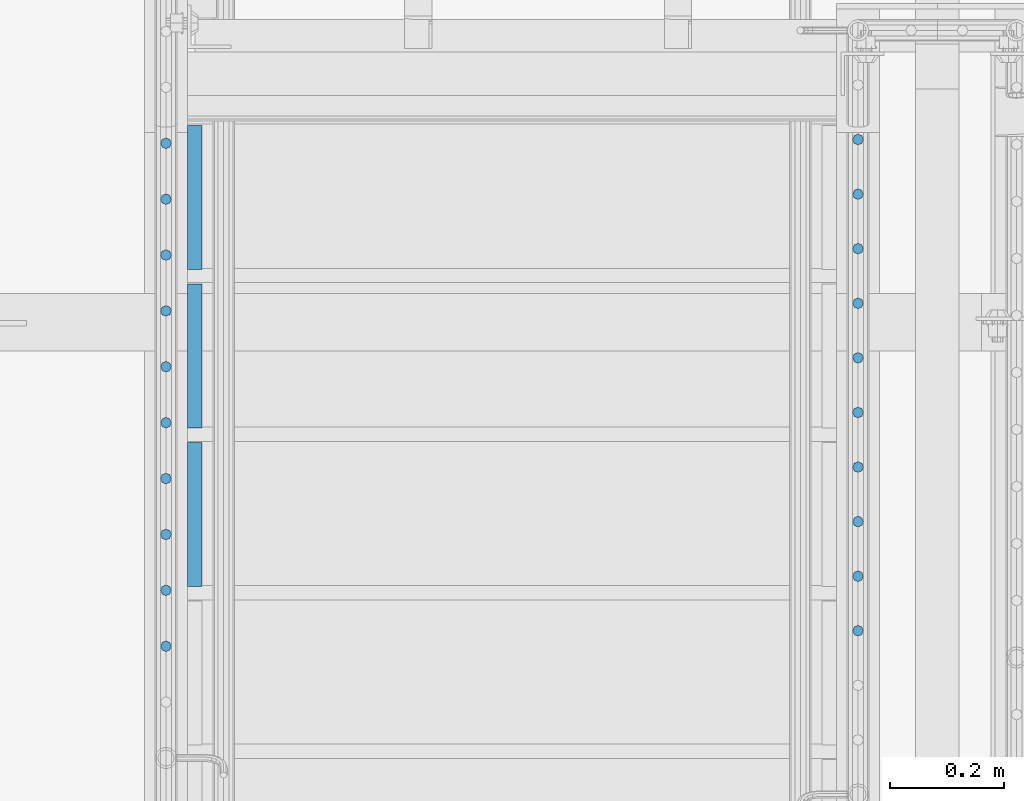
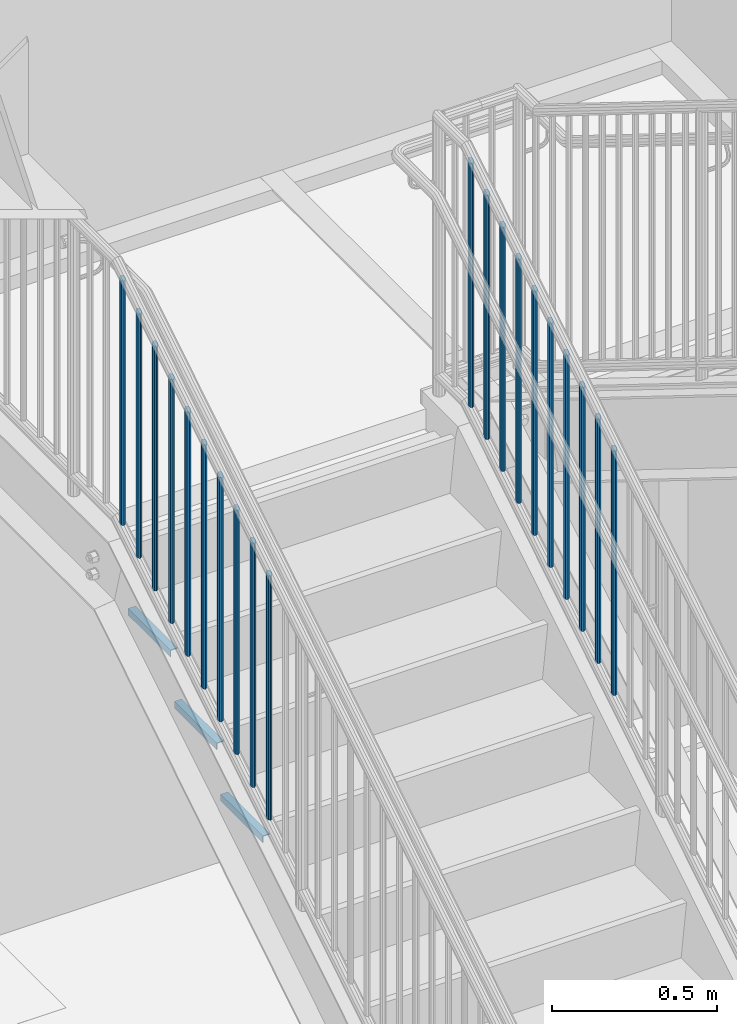
# One storey, part 1271 of 1763: 23 beams, 3 elements without a shape of their own.
"""IFC2X3 building model written with IfcOpenShell, lengths in millimetres."""

from ifc_helpers import new_model, si_unit, frame, origin_with_axes, place, context, subcontext, project, spatial, faceted_brep, material, type_object, element, aggregate, save


model = new_model("IFC2X3")

# Units and contexts
model_context = context("Model", 3, precision=1e-05, world=origin_with_axes())
body_context = subcontext(model_context, "Body", "Model", "MODEL_VIEW")
ifc_project = project(units=[si_unit("LENGTHUNIT", "METRE", prefix="MILLI"), si_unit("AREAUNIT", "SQUARE_METRE"), si_unit("VOLUMEUNIT", "CUBIC_METRE"), si_unit("MASSUNIT", "GRAM", prefix="KILO"), si_unit("TIMEUNIT", "SECOND"), si_unit("PLANEANGLEUNIT", "RADIAN"), si_unit("SOLIDANGLEUNIT", "STERADIAN"), si_unit("THERMODYNAMICTEMPERATUREUNIT", "DEGREE_CELSIUS"), si_unit("LUMINOUSINTENSITYUNIT", "LUMEN")], contexts=[model_context])

# Site, building, storey
site_placement = place(None, origin_with_axes())
site = spatial("IfcSite", under=ifc_project, at=site_placement, CompositionType="ELEMENT")
building_placement = place(site_placement, origin_with_axes())
building = spatial("IfcBuilding", under=site, at=building_placement, Name="Undefined", CompositionType="ELEMENT")
storey_placement = place(building_placement, origin_with_axes())
storey = spatial("IfcBuildingStorey", under=building, at=storey_placement, Name="Undefined", CompositionType="ELEMENT", Elevation=0.0)

# Assembly, beams
assembly_1_placement = place(storey_placement, origin_with_axes())
assembly_1 = element("IfcElementAssembly", 1, at=assembly_1_placement, inside=storey, Name="RAIL", AssemblyPlace="NOTDEFINED", PredefinedType="RIGID_FRAME")
ifc_material = material(Name="STEEL/A36")
beam_type_1 = type_object("IfcBeamType", PredefinedType="NOTDEFINED")
beam_1_placement = place(assembly_1_placement, frame((-85559.3372736932, 35901.0857146553, 3782.00006697853), z_axis=(-1.0, 0.0, 0.0), x_axis=(0.0, 0.0, -1.0)))
beam_1 = element("IfcBeam", 2, at=beam_1_placement, type_object=beam_type_1, material=ifc_material, Name="PICKET", context=body_context, shape_type="Brep", body=[
    faceted_brep([(18.2402825153672, -6.73519209080405, 6.73519209079677), (22.4197092545201, 0.0, 9.52499999999418), (26.5991359936734, 6.73519209080405, 6.73519209079677), (28.330311231975, 9.52500000000146, 0.0), (26.5991359936734, 6.73519209080405, -6.73519209079677), (22.4197092545201, 0.0, -9.52499999999418), (18.2402825153672, -6.73519209080405, -6.73519209079677), (16.5091072770651, -9.52500000000146, 0.0), (929.64089275145, 9.52500000000146, 0.0), (927.909717513148, 6.73519209080405, -6.73519209079677), (923.730290773995, 0.0, -9.52499999999418), (919.550864034841, -6.73519209080405, -6.73519209079677), (917.819688796539, -9.52500000000146, 0.0), (919.550864034841, -6.73519209080405, 6.73519209079677), (923.730290773995, 0.0, 9.52499999999418), (927.909717513148, 6.73519209080405, 6.73519209079677)], [[[0, 1, 2, 3, 4, 5, 6, 7]], [[4, 3, 8, 9]], [[5, 4, 9, 10]], [[6, 5, 10, 11]], [[7, 6, 11, 12]], [[0, 7, 12, 13]], [[1, 0, 13, 14]], [[2, 1, 14, 15]], [[3, 2, 15, 8]], [[14, 13, 12, 11, 10, 9, 8, 15]]]),
])
beam_2_placement = place(assembly_1_placement, frame((-85559.3372736932, 35804.9285717983, 3722.33113272945), z_axis=(-1.0, 0.0, 0.0), x_axis=(0.0, 0.0, -1.0)))
beam_2 = element("IfcBeam", 3, at=beam_2_placement, type_object=beam_type_1, material=ifc_material, Name="PICKET", context=body_context, shape_type="Brep", body=[
    faceted_brep([(16.5091072770651, -9.52500000000146, 0.0), (18.2402825153672, -6.73519209080405, -6.73519209079677), (919.550864034841, -6.73519209080405, -6.73519209079677), (917.819688796539, -9.52500000000146, 0.0), (22.4197092545201, 0.0, -9.52499999999418), (923.730290773995, 0.0, -9.52499999999418), (26.5991359936734, 6.73519209080405, -6.73519209079677), (927.909717513148, 6.73519209080405, -6.73519209079677), (28.330311231975, 9.52500000000146, 0.0), (929.64089275145, 9.52500000000146, 0.0), (26.5991359936734, 6.73519209080405, 6.73519209079677), (927.909717513148, 6.73519209080405, 6.73519209079677), (22.4197092545201, 0.0, 9.52499999999418), (923.730290773995, 0.0, 9.52499999999418), (18.2402825153672, -6.73519209080405, 6.73519209079677), (919.550864034841, -6.73519209080405, 6.73519209079677)], [[[0, 1, 2, 3]], [[1, 4, 5, 2]], [[4, 6, 7, 5]], [[6, 8, 9, 7]], [[8, 10, 11, 9]], [[10, 12, 13, 11]], [[12, 14, 15, 13]], [[14, 0, 3, 15]], [[13, 15, 3, 2, 5, 7, 9, 11]], [[14, 12, 10, 8, 6, 4, 1, 0]]]),
])
beam_3_placement = place(assembly_1_placement, frame((-85559.3372736932, 35708.7714289412, 3662.66219848037), z_axis=(-1.0, 0.0, 0.0), x_axis=(0.0, 0.0, -1.0)))
beam_3 = element("IfcBeam", 4, at=beam_3_placement, type_object=beam_type_1, material=ifc_material, Name="PICKET", context=body_context, shape_type="Brep", body=[
    faceted_brep([(16.5091072770651, -9.52500000000146, 0.0), (18.2402825153672, -6.73519209080405, -6.73519209079677), (919.550864034841, -6.73519209080405, -6.73519209079677), (917.819688796539, -9.52500000000146, 0.0), (22.4197092545201, 0.0, -9.52499999999418), (923.730290773995, 0.0, -9.52499999999418), (26.5991359936734, 6.73519209080405, -6.73519209079677), (927.909717513148, 6.73519209080405, -6.73519209079677), (28.330311231975, 9.52500000000146, 0.0), (929.64089275145, 9.52500000000146, 0.0), (26.5991359936734, 6.73519209080405, 6.73519209079677), (927.909717513148, 6.73519209080405, 6.73519209079677), (22.4197092545201, 0.0, 9.52499999999418), (923.730290773995, 0.0, 9.52499999999418), (18.2402825153672, -6.73519209080405, 6.73519209079677), (919.550864034841, -6.73519209080405, 6.73519209079677)], [[[0, 1, 2, 3]], [[1, 4, 5, 2]], [[4, 6, 7, 5]], [[6, 8, 9, 7]], [[8, 10, 11, 9]], [[10, 12, 13, 11]], [[12, 14, 15, 13]], [[14, 0, 3, 15]], [[13, 15, 3, 2, 5, 7, 9, 11]], [[14, 12, 10, 8, 6, 4, 1, 0]]]),
])
beam_4_placement = place(assembly_1_placement, frame((-85559.3372736932, 35612.6142860842, 3602.9932642313), z_axis=(-1.0, 0.0, 0.0), x_axis=(0.0, 0.0, -1.0)))
beam_4 = element("IfcBeam", 5, at=beam_4_placement, type_object=beam_type_1, material=ifc_material, Name="PICKET", context=body_context, shape_type="Brep", body=[
    faceted_brep([(16.5091072770651, -9.52500000000146, 0.0), (18.2402825153672, -6.73519209080405, -6.73519209079677), (919.550864034841, -6.73519209080405, -6.73519209079677), (917.819688796539, -9.52500000000146, 0.0), (22.4197092545201, 0.0, -9.52499999999418), (923.730290773995, 0.0, -9.52499999999418), (26.5991359936734, 6.73519209080405, -6.73519209079677), (927.909717513148, 6.73519209080405, -6.73519209079677), (28.330311231975, 9.52500000000146, 0.0), (929.64089275145, 9.52500000000146, 0.0), (26.5991359936734, 6.73519209080405, 6.73519209079677), (927.909717513148, 6.73519209080405, 6.73519209079677), (22.4197092545201, 0.0, 9.52499999999418), (923.730290773995, 0.0, 9.52499999999418), (18.2402825153672, -6.73519209080405, 6.73519209079677), (919.550864034841, -6.73519209080405, 6.73519209079677)], [[[0, 1, 2, 3]], [[1, 4, 5, 2]], [[4, 6, 7, 5]], [[6, 8, 9, 7]], [[8, 10, 11, 9]], [[10, 12, 13, 11]], [[12, 14, 15, 13]], [[14, 0, 3, 15]], [[13, 15, 3, 2, 5, 7, 9, 11]], [[14, 12, 10, 8, 6, 4, 1, 0]]]),
])
beam_5_placement = place(assembly_1_placement, frame((-85559.3372736932, 35516.4571432272, 3543.32432998222), z_axis=(-1.0, 0.0, 0.0), x_axis=(0.0, 0.0, -1.0)))
beam_5 = element("IfcBeam", 6, at=beam_5_placement, type_object=beam_type_1, material=ifc_material, Name="PICKET", context=body_context, shape_type="Brep", body=[
    faceted_brep([(16.5091072770651, -9.52500000000146, 0.0), (18.2402825153672, -6.73519209080405, -6.73519209079677), (919.550864034841, -6.73519209080405, -6.73519209079677), (917.819688796539, -9.52500000000146, 0.0), (22.4197092545201, 0.0, -9.52499999999418), (923.730290773995, 0.0, -9.52499999999418), (26.5991359936734, 6.73519209080405, -6.73519209079677), (927.909717513148, 6.73519209080405, -6.73519209079677), (28.330311231975, 9.52500000000146, 0.0), (929.64089275145, 9.52500000000146, 0.0), (26.5991359936734, 6.73519209080405, 6.73519209079677), (927.909717513148, 6.73519209080405, 6.73519209079677), (22.4197092545201, 0.0, 9.52499999999418), (923.730290773995, 0.0, 9.52499999999418), (18.2402825153672, -6.73519209080405, 6.73519209079677), (919.550864034841, -6.73519209080405, 6.73519209079677)], [[[0, 1, 2, 3]], [[1, 4, 5, 2]], [[4, 6, 7, 5]], [[6, 8, 9, 7]], [[8, 10, 11, 9]], [[10, 12, 13, 11]], [[12, 14, 15, 13]], [[14, 0, 3, 15]], [[13, 15, 3, 2, 5, 7, 9, 11]], [[14, 12, 10, 8, 6, 4, 1, 0]]]),
])
beam_6_placement = place(assembly_1_placement, frame((-85559.3372736932, 35420.3000003702, 3483.65539573314), z_axis=(-1.0, 0.0, 0.0), x_axis=(0.0, 0.0, -1.0)))
beam_6 = element("IfcBeam", 7, at=beam_6_placement, type_object=beam_type_1, material=ifc_material, Name="PICKET", context=body_context, shape_type="Brep", body=[
    faceted_brep([(16.5091072770651, -9.52500000000146, 0.0), (18.2402825153672, -6.73519209080405, -6.73519209079677), (919.550864034841, -6.73519209080405, -6.73519209079677), (917.819688796539, -9.52500000000146, 0.0), (22.4197092545201, 0.0, -9.52499999999418), (923.730290773995, 0.0, -9.52499999999418), (26.5991359936734, 6.73519209080405, -6.73519209079677), (927.909717513148, 6.73519209080405, -6.73519209079677), (28.330311231975, 9.52500000000146, 0.0), (929.64089275145, 9.52500000000146, 0.0), (26.5991359936734, 6.73519209080405, 6.73519209079677), (927.909717513148, 6.73519209080405, 6.73519209079677), (22.4197092545201, 0.0, 9.52499999999418), (923.730290773995, 0.0, 9.52499999999418), (18.2402825153672, -6.73519209080405, 6.73519209079677), (919.550864034841, -6.73519209080405, 6.73519209079677)], [[[0, 1, 2, 3]], [[1, 4, 5, 2]], [[4, 6, 7, 5]], [[6, 8, 9, 7]], [[8, 10, 11, 9]], [[10, 12, 13, 11]], [[12, 14, 15, 13]], [[14, 0, 3, 15]], [[13, 15, 3, 2, 5, 7, 9, 11]], [[14, 12, 10, 8, 6, 4, 1, 0]]]),
])
beam_7_placement = place(assembly_1_placement, frame((-85559.3372736932, 35324.1428575132, 3423.98646148406), z_axis=(-1.0, 0.0, 0.0), x_axis=(0.0, 0.0, -1.0)))
beam_7 = element("IfcBeam", 8, at=beam_7_placement, type_object=beam_type_1, material=ifc_material, Name="PICKET", context=body_context, shape_type="Brep", body=[
    faceted_brep([(16.5091072770651, -9.52500000000146, 0.0), (18.2402825153672, -6.73519209080405, -6.73519209079677), (919.550864034841, -6.73519209080405, -6.73519209079677), (917.819688796539, -9.52500000000146, 0.0), (22.4197092545201, 0.0, -9.52499999999418), (923.730290773995, 0.0, -9.52499999999418), (26.5991359936734, 6.73519209080405, -6.73519209079677), (927.909717513148, 6.73519209080405, -6.73519209079677), (28.330311231975, 9.52500000000146, 0.0), (929.64089275145, 9.52500000000146, 0.0), (26.5991359936734, 6.73519209080405, 6.73519209079677), (927.909717513148, 6.73519209080405, 6.73519209079677), (22.4197092545201, 0.0, 9.52499999999418), (923.730290773995, 0.0, 9.52499999999418), (18.2402825153672, -6.73519209080405, 6.73519209079677), (919.550864034841, -6.73519209080405, 6.73519209079677)], [[[0, 1, 2, 3]], [[1, 4, 5, 2]], [[4, 6, 7, 5]], [[6, 8, 9, 7]], [[8, 10, 11, 9]], [[10, 12, 13, 11]], [[12, 14, 15, 13]], [[14, 0, 3, 15]], [[13, 15, 3, 2, 5, 7, 9, 11]], [[14, 12, 10, 8, 6, 4, 1, 0]]]),
])
beam_8_placement = place(assembly_1_placement, frame((-85559.3372736932, 35227.9857146562, 3364.31752723499), z_axis=(-1.0, 0.0, 0.0), x_axis=(0.0, 0.0, -1.0)))
beam_8 = element("IfcBeam", 9, at=beam_8_placement, type_object=beam_type_1, material=ifc_material, Name="PICKET", context=body_context, shape_type="Brep", body=[
    faceted_brep([(16.5091072770651, -9.52500000000146, 0.0), (18.2402825153672, -6.73519209080405, -6.73519209079677), (919.550864034841, -6.73519209080405, -6.73519209079677), (917.819688796539, -9.52500000000146, 0.0), (22.4197092545201, 0.0, -9.52499999999418), (923.730290773995, 0.0, -9.52499999999418), (26.5991359936734, 6.73519209080405, -6.73519209079677), (927.909717513148, 6.73519209080405, -6.73519209079677), (28.330311231975, 9.52500000000146, 0.0), (929.64089275145, 9.52500000000146, 0.0), (26.5991359936734, 6.73519209080405, 6.73519209079677), (927.909717513148, 6.73519209080405, 6.73519209079677), (22.4197092545201, 0.0, 9.52499999999418), (923.730290773995, 0.0, 9.52499999999418), (18.2402825153672, -6.73519209080405, 6.73519209079677), (919.550864034841, -6.73519209080405, 6.73519209079677)], [[[0, 1, 2, 3]], [[1, 4, 5, 2]], [[4, 6, 7, 5]], [[6, 8, 9, 7]], [[8, 10, 11, 9]], [[10, 12, 13, 11]], [[12, 14, 15, 13]], [[14, 0, 3, 15]], [[13, 15, 3, 2, 5, 7, 9, 11]], [[14, 12, 10, 8, 6, 4, 1, 0]]]),
])
beam_9_placement = place(assembly_1_placement, frame((-85559.3372736932, 35131.8285717991, 3304.64859298591), z_axis=(-1.0, 0.0, 0.0), x_axis=(0.0, 0.0, -1.0)))
beam_9 = element("IfcBeam", 10, at=beam_9_placement, type_object=beam_type_1, material=ifc_material, Name="PICKET", context=body_context, shape_type="Brep", body=[
    faceted_brep([(16.5091072770651, -9.52500000000146, 0.0), (18.2402825153672, -6.73519209080405, -6.73519209079677), (919.550864034841, -6.73519209080405, -6.73519209079677), (917.819688796539, -9.52500000000146, 0.0), (22.4197092545201, 0.0, -9.52499999999418), (923.730290773995, 0.0, -9.52499999999418), (26.5991359936734, 6.73519209080405, -6.73519209079677), (927.909717513148, 6.73519209080405, -6.73519209079677), (28.330311231975, 9.52500000000146, 0.0), (929.64089275145, 9.52500000000146, 0.0), (26.5991359936734, 6.73519209080405, 6.73519209079677), (927.909717513148, 6.73519209080405, 6.73519209079677), (22.4197092545201, 0.0, 9.52499999999418), (923.730290773995, 0.0, 9.52499999999418), (18.2402825153672, -6.73519209080405, 6.73519209079677), (919.550864034841, -6.73519209080405, 6.73519209079677)], [[[0, 1, 2, 3]], [[1, 4, 5, 2]], [[4, 6, 7, 5]], [[6, 8, 9, 7]], [[8, 10, 11, 9]], [[10, 12, 13, 11]], [[12, 14, 15, 13]], [[14, 0, 3, 15]], [[13, 15, 3, 2, 5, 7, 9, 11]], [[14, 12, 10, 8, 6, 4, 1, 0]]]),
])
beam_10_placement = place(assembly_1_placement, frame((-85559.3372736932, 35035.6714289421, 3244.97965873683), z_axis=(-1.0, 0.0, 0.0), x_axis=(0.0, 0.0, -1.0)))
beam_10 = element("IfcBeam", 11, at=beam_10_placement, type_object=beam_type_1, material=ifc_material, Name="PICKET", context=body_context, shape_type="Brep", body=[
    faceted_brep([(16.5091072770651, -9.52500000000146, 0.0), (18.2402825153672, -6.73519209080405, -6.73519209079677), (919.550864034841, -6.73519209080405, -6.73519209079677), (917.819688796539, -9.52500000000146, 0.0), (22.4197092545201, 0.0, -9.52499999999418), (923.730290773995, 0.0, -9.52499999999418), (26.5991359936734, 6.73519209080405, -6.73519209079677), (927.909717513148, 6.73519209080405, -6.73519209079677), (28.330311231975, 9.52500000000146, 0.0), (929.64089275145, 9.52500000000146, 0.0), (26.5991359936734, 6.73519209080405, 6.73519209079677), (927.909717513148, 6.73519209080405, 6.73519209079677), (22.4197092545201, 0.0, 9.52499999999418), (923.730290773995, 0.0, 9.52499999999418), (18.2402825153672, -6.73519209080405, 6.73519209079677), (919.550864034841, -6.73519209080405, 6.73519209079677)], [[[0, 1, 2, 3]], [[1, 4, 5, 2]], [[4, 6, 7, 5]], [[6, 8, 9, 7]], [[8, 10, 11, 9]], [[10, 12, 13, 11]], [[12, 14, 15, 13]], [[14, 0, 3, 15]], [[13, 15, 3, 2, 5, 7, 9, 11]], [[14, 12, 10, 8, 6, 4, 1, 0]]]),
])
aggregate(assembly_1, [beam_1, beam_2, beam_3, beam_4, beam_5, beam_6, beam_7, beam_8, beam_9, beam_10])

assembly_2_placement = place(storey_placement, origin_with_axes())
assembly_2 = element("IfcElementAssembly", 12, at=assembly_2_placement, inside=storey, Name="RAIL", AssemblyPlace="NOTDEFINED", PredefinedType="RIGID_FRAME")
beam_11_placement = place(assembly_2_placement, frame((-86778.5372736927, 35894.5542860836, 3777.94708275635), z_axis=(-1.0, 0.0, 0.0), x_axis=(0.0, 0.0, -1.0)))
beam_11 = element("IfcBeam", 13, at=beam_11_placement, type_object=beam_type_1, material=ifc_material, Name="PICKET", context=body_context, shape_type="Brep", body=[
    faceted_brep([(18.2402825153672, -6.73519209080405, 6.73519209079677), (22.4197092545201, 0.0, 9.52499999999418), (26.5991359936734, 6.73519209080405, 6.73519209079677), (28.330311231975, 9.52500000000146, 0.0), (26.5991359936734, 6.73519209080405, -6.73519209079677), (22.4197092545201, 0.0, -9.52499999999418), (18.2402825153672, -6.73519209080405, -6.73519209079677), (16.5091072770651, -9.52500000000146, 0.0), (929.64089275145, 9.52500000000146, 0.0), (927.909717513148, 6.73519209080405, -6.73519209079677), (923.730290773995, 0.0, -9.52499999999418), (919.550864034841, -6.73519209080405, -6.73519209079677), (917.819688796539, -9.52500000000146, 0.0), (919.550864034841, -6.73519209080405, 6.73519209079677), (923.730290773995, 0.0, 9.52499999999418), (927.909717513148, 6.73519209080405, 6.73519209079677)], [[[0, 1, 2, 3, 4, 5, 6, 7]], [[4, 3, 8, 9]], [[5, 4, 9, 10]], [[6, 5, 10, 11]], [[7, 6, 11, 12]], [[0, 7, 12, 13]], [[1, 0, 13, 14]], [[2, 1, 14, 15]], [[3, 2, 15, 8]], [[14, 13, 12, 11, 10, 9, 8, 15]]]),
])
beam_12_placement = place(assembly_2_placement, frame((-86778.5372736927, 35796.0990479883, 3716.85209850662), z_axis=(-1.0, 0.0, 0.0), x_axis=(0.0, 0.0, -1.0)))
beam_12 = element("IfcBeam", 14, at=beam_12_placement, type_object=beam_type_1, material=ifc_material, Name="PICKET", context=body_context, shape_type="Brep", body=[
    faceted_brep([(16.5091072770651, -9.52500000000146, 0.0), (18.2402825153672, -6.73519209080405, -6.73519209079677), (919.550864034841, -6.73519209080405, -6.73519209079677), (917.819688796539, -9.52500000000146, 0.0), (22.4197092545201, 0.0, -9.52499999999418), (923.730290773995, 0.0, -9.52499999999418), (26.5991359936734, 6.73519209080405, -6.73519209079677), (927.909717513148, 6.73519209080405, -6.73519209079677), (28.330311231975, 9.52500000000146, 0.0), (929.64089275145, 9.52500000000146, 0.0), (26.5991359936734, 6.73519209080405, 6.73519209079677), (927.909717513148, 6.73519209080405, 6.73519209079677), (22.4197092545201, 0.0, 9.52499999999418), (923.730290773995, 0.0, 9.52499999999418), (18.2402825153672, -6.73519209080405, 6.73519209079677), (919.550864034841, -6.73519209080405, 6.73519209079677)], [[[0, 1, 2, 3]], [[1, 4, 5, 2]], [[4, 6, 7, 5]], [[6, 8, 9, 7]], [[8, 10, 11, 9]], [[10, 12, 13, 11]], [[12, 14, 15, 13]], [[14, 0, 3, 15]], [[13, 15, 3, 2, 5, 7, 9, 11]], [[14, 12, 10, 8, 6, 4, 1, 0]]]),
])
beam_13_placement = place(assembly_2_placement, frame((-86778.5372736927, 35697.6438098931, 3655.75711425689), z_axis=(-1.0, 0.0, 0.0), x_axis=(0.0, 0.0, -1.0)))
beam_13 = element("IfcBeam", 15, at=beam_13_placement, type_object=beam_type_1, material=ifc_material, Name="PICKET", context=body_context, shape_type="Brep", body=[
    faceted_brep([(16.5091072770651, -9.52500000000146, 0.0), (18.2402825153672, -6.73519209080405, -6.73519209079677), (919.550864034841, -6.73519209080405, -6.73519209079677), (917.819688796539, -9.52500000000146, 0.0), (22.4197092545201, 0.0, -9.52499999999418), (923.730290773995, 0.0, -9.52499999999418), (26.5991359936734, 6.73519209080405, -6.73519209079677), (927.909717513148, 6.73519209080405, -6.73519209079677), (28.330311231975, 9.52500000000146, 0.0), (929.64089275145, 9.52500000000146, 0.0), (26.5991359936734, 6.73519209080405, 6.73519209079677), (927.909717513148, 6.73519209080405, 6.73519209079677), (22.4197092545201, 0.0, 9.52499999999418), (923.730290773995, 0.0, 9.52499999999418), (18.2402825153672, -6.73519209080405, 6.73519209079677), (919.550864034841, -6.73519209080405, 6.73519209079677)], [[[0, 1, 2, 3]], [[1, 4, 5, 2]], [[4, 6, 7, 5]], [[6, 8, 9, 7]], [[8, 10, 11, 9]], [[10, 12, 13, 11]], [[12, 14, 15, 13]], [[14, 0, 3, 15]], [[13, 15, 3, 2, 5, 7, 9, 11]], [[14, 12, 10, 8, 6, 4, 1, 0]]]),
])
beam_14_placement = place(assembly_2_placement, frame((-86778.5372736927, 35599.1885717979, 3594.66213000716), z_axis=(-1.0, 0.0, 0.0), x_axis=(0.0, 0.0, -1.0)))
beam_14 = element("IfcBeam", 16, at=beam_14_placement, type_object=beam_type_1, material=ifc_material, Name="PICKET", context=body_context, shape_type="Brep", body=[
    faceted_brep([(16.5091072770651, -9.52500000000146, 0.0), (18.2402825153672, -6.73519209080405, -6.73519209079677), (919.550864034841, -6.73519209080405, -6.73519209079677), (917.819688796539, -9.52500000000146, 0.0), (22.4197092545201, 0.0, -9.52499999999418), (923.730290773995, 0.0, -9.52499999999418), (26.5991359936734, 6.73519209080405, -6.73519209079677), (927.909717513148, 6.73519209080405, -6.73519209079677), (28.330311231975, 9.52500000000146, 0.0), (929.64089275145, 9.52500000000146, 0.0), (26.5991359936734, 6.73519209080405, 6.73519209079677), (927.909717513148, 6.73519209080405, 6.73519209079677), (22.4197092545201, 0.0, 9.52499999999418), (923.730290773995, 0.0, 9.52499999999418), (18.2402825153672, -6.73519209080405, 6.73519209079677), (919.550864034841, -6.73519209080405, 6.73519209079677)], [[[0, 1, 2, 3]], [[1, 4, 5, 2]], [[4, 6, 7, 5]], [[6, 8, 9, 7]], [[8, 10, 11, 9]], [[10, 12, 13, 11]], [[12, 14, 15, 13]], [[14, 0, 3, 15]], [[13, 15, 3, 2, 5, 7, 9, 11]], [[14, 12, 10, 8, 6, 4, 1, 0]]]),
])
beam_15_placement = place(assembly_2_placement, frame((-86778.5372736927, 35500.7333337026, 3533.56714575743), z_axis=(-1.0, 0.0, 0.0), x_axis=(0.0, 0.0, -1.0)))
beam_15 = element("IfcBeam", 17, at=beam_15_placement, type_object=beam_type_1, material=ifc_material, Name="PICKET", context=body_context, shape_type="Brep", body=[
    faceted_brep([(16.5091072770651, -9.52500000000146, 0.0), (18.2402825153672, -6.73519209080405, -6.73519209079677), (919.550864034841, -6.73519209080405, -6.73519209079677), (917.819688796539, -9.52500000000146, 0.0), (22.4197092545201, 0.0, -9.52499999999418), (923.730290773995, 0.0, -9.52499999999418), (26.5991359936734, 6.73519209080405, -6.73519209079677), (927.909717513148, 6.73519209080405, -6.73519209079677), (28.330311231975, 9.52500000000146, 0.0), (929.64089275145, 9.52500000000146, 0.0), (26.5991359936734, 6.73519209080405, 6.73519209079677), (927.909717513148, 6.73519209080405, 6.73519209079677), (22.4197092545201, 0.0, 9.52499999999418), (923.730290773995, 0.0, 9.52499999999418), (18.2402825153672, -6.73519209080405, 6.73519209079677), (919.550864034841, -6.73519209080405, 6.73519209079677)], [[[0, 1, 2, 3]], [[1, 4, 5, 2]], [[4, 6, 7, 5]], [[6, 8, 9, 7]], [[8, 10, 11, 9]], [[10, 12, 13, 11]], [[12, 14, 15, 13]], [[14, 0, 3, 15]], [[13, 15, 3, 2, 5, 7, 9, 11]], [[14, 12, 10, 8, 6, 4, 1, 0]]]),
])
beam_16_placement = place(assembly_2_placement, frame((-86778.5372736927, 35402.2780956074, 3472.4721615077), z_axis=(-1.0, 0.0, 0.0), x_axis=(0.0, 0.0, -1.0)))
beam_16 = element("IfcBeam", 18, at=beam_16_placement, type_object=beam_type_1, material=ifc_material, Name="PICKET", context=body_context, shape_type="Brep", body=[
    faceted_brep([(16.5091072770651, -9.52500000000146, 0.0), (18.2402825153672, -6.73519209080405, -6.73519209079677), (919.550864034841, -6.73519209080405, -6.73519209079677), (917.819688796539, -9.52500000000146, 0.0), (22.4197092545201, 0.0, -9.52499999999418), (923.730290773995, 0.0, -9.52499999999418), (26.5991359936734, 6.73519209080405, -6.73519209079677), (927.909717513148, 6.73519209080405, -6.73519209079677), (28.330311231975, 9.52500000000146, 0.0), (929.64089275145, 9.52500000000146, 0.0), (26.5991359936734, 6.73519209080405, 6.73519209079677), (927.909717513148, 6.73519209080405, 6.73519209079677), (22.4197092545201, 0.0, 9.52499999999418), (923.730290773995, 0.0, 9.52499999999418), (18.2402825153672, -6.73519209080405, 6.73519209079677), (919.550864034841, -6.73519209080405, 6.73519209079677)], [[[0, 1, 2, 3]], [[1, 4, 5, 2]], [[4, 6, 7, 5]], [[6, 8, 9, 7]], [[8, 10, 11, 9]], [[10, 12, 13, 11]], [[12, 14, 15, 13]], [[14, 0, 3, 15]], [[13, 15, 3, 2, 5, 7, 9, 11]], [[14, 12, 10, 8, 6, 4, 1, 0]]]),
])
beam_17_placement = place(assembly_2_placement, frame((-86778.5372736927, 35303.8228575122, 3411.37717725797), z_axis=(-1.0, 0.0, 0.0), x_axis=(0.0, 0.0, -1.0)))
beam_17 = element("IfcBeam", 19, at=beam_17_placement, type_object=beam_type_1, material=ifc_material, Name="PICKET", context=body_context, shape_type="Brep", body=[
    faceted_brep([(16.5091072770651, -9.52500000000146, 0.0), (18.2402825153672, -6.73519209080405, -6.73519209079677), (919.550864034841, -6.73519209080405, -6.73519209079677), (917.819688796539, -9.52500000000146, 0.0), (22.4197092545201, 0.0, -9.52499999999418), (923.730290773995, 0.0, -9.52499999999418), (26.5991359936734, 6.73519209080405, -6.73519209079677), (927.909717513148, 6.73519209080405, -6.73519209079677), (28.330311231975, 9.52500000000146, 0.0), (929.64089275145, 9.52500000000146, 0.0), (26.5991359936734, 6.73519209080405, 6.73519209079677), (927.909717513148, 6.73519209080405, 6.73519209079677), (22.4197092545201, 0.0, 9.52499999999418), (923.730290773995, 0.0, 9.52499999999418), (18.2402825153672, -6.73519209080405, 6.73519209079677), (919.550864034841, -6.73519209080405, 6.73519209079677)], [[[0, 1, 2, 3]], [[1, 4, 5, 2]], [[4, 6, 7, 5]], [[6, 8, 9, 7]], [[8, 10, 11, 9]], [[10, 12, 13, 11]], [[12, 14, 15, 13]], [[14, 0, 3, 15]], [[13, 15, 3, 2, 5, 7, 9, 11]], [[14, 12, 10, 8, 6, 4, 1, 0]]]),
])
beam_18_placement = place(assembly_2_placement, frame((-86778.5372736927, 35205.3676194169, 3350.28219300824), z_axis=(-1.0, 0.0, 0.0), x_axis=(0.0, 0.0, -1.0)))
beam_18 = element("IfcBeam", 20, at=beam_18_placement, type_object=beam_type_1, material=ifc_material, Name="PICKET", context=body_context, shape_type="Brep", body=[
    faceted_brep([(16.5091072770651, -9.52500000000146, 0.0), (18.2402825153672, -6.73519209080405, -6.73519209079677), (919.550864034841, -6.73519209080405, -6.73519209079677), (917.819688796539, -9.52500000000146, 0.0), (22.4197092545201, 0.0, -9.52499999999418), (923.730290773995, 0.0, -9.52499999999418), (26.5991359936734, 6.73519209080405, -6.73519209079677), (927.909717513148, 6.73519209080405, -6.73519209079677), (28.330311231975, 9.52500000000146, 0.0), (929.64089275145, 9.52500000000146, 0.0), (26.5991359936734, 6.73519209080405, 6.73519209079677), (927.909717513148, 6.73519209080405, 6.73519209079677), (22.4197092545201, 0.0, 9.52499999999418), (923.730290773995, 0.0, 9.52499999999418), (18.2402825153672, -6.73519209080405, 6.73519209079677), (919.550864034841, -6.73519209080405, 6.73519209079677)], [[[0, 1, 2, 3]], [[1, 4, 5, 2]], [[4, 6, 7, 5]], [[6, 8, 9, 7]], [[8, 10, 11, 9]], [[10, 12, 13, 11]], [[12, 14, 15, 13]], [[14, 0, 3, 15]], [[13, 15, 3, 2, 5, 7, 9, 11]], [[14, 12, 10, 8, 6, 4, 1, 0]]]),
])
beam_19_placement = place(assembly_2_placement, frame((-86778.5372736927, 35106.9123813217, 3289.18720875851), z_axis=(-1.0, 0.0, 0.0), x_axis=(0.0, 0.0, -1.0)))
beam_19 = element("IfcBeam", 21, at=beam_19_placement, type_object=beam_type_1, material=ifc_material, Name="PICKET", context=body_context, shape_type="Brep", body=[
    faceted_brep([(16.5091072770651, -9.52500000000146, 0.0), (18.2402825153672, -6.73519209080405, -6.73519209079677), (919.550864034841, -6.73519209080405, -6.73519209079677), (917.819688796539, -9.52500000000146, 0.0), (22.4197092545201, 0.0, -9.52499999999418), (923.730290773995, 0.0, -9.52499999999418), (26.5991359936734, 6.73519209080405, -6.73519209079677), (927.909717513148, 6.73519209080405, -6.73519209079677), (28.330311231975, 9.52500000000146, 0.0), (929.64089275145, 9.52500000000146, 0.0), (26.5991359936734, 6.73519209080405, 6.73519209079677), (927.909717513148, 6.73519209080405, 6.73519209079677), (22.4197092545201, 0.0, 9.52499999999418), (923.730290773995, 0.0, 9.52499999999418), (18.2402825153672, -6.73519209080405, 6.73519209079677), (919.550864034841, -6.73519209080405, 6.73519209079677)], [[[0, 1, 2, 3]], [[1, 4, 5, 2]], [[4, 6, 7, 5]], [[6, 8, 9, 7]], [[8, 10, 11, 9]], [[10, 12, 13, 11]], [[12, 14, 15, 13]], [[14, 0, 3, 15]], [[13, 15, 3, 2, 5, 7, 9, 11]], [[14, 12, 10, 8, 6, 4, 1, 0]]]),
])
beam_20_placement = place(assembly_2_placement, frame((-86778.5372736927, 35008.4571432264, 3228.09222450878), z_axis=(-1.0, 0.0, 0.0), x_axis=(0.0, 0.0, -1.0)))
beam_20 = element("IfcBeam", 22, at=beam_20_placement, type_object=beam_type_1, material=ifc_material, Name="PICKET", context=body_context, shape_type="Brep", body=[
    faceted_brep([(16.5091072770651, -9.52500000000146, 0.0), (18.2402825153672, -6.73519209080405, -6.73519209079677), (919.550864034841, -6.73519209080405, -6.73519209079677), (917.819688796539, -9.52500000000146, 0.0), (22.4197092545201, 0.0, -9.52499999999418), (923.730290773995, 0.0, -9.52499999999418), (26.5991359936734, 6.73519209080405, -6.73519209079677), (927.909717513148, 6.73519209080405, -6.73519209079677), (28.330311231975, 9.52500000000146, 0.0), (929.64089275145, 9.52500000000146, 0.0), (26.5991359936734, 6.73519209080405, 6.73519209079677), (927.909717513148, 6.73519209080405, 6.73519209079677), (22.4197092545201, 0.0, 9.52499999999418), (923.730290773995, 0.0, 9.52499999999418), (18.2402825153672, -6.73519209080405, 6.73519209079677), (919.550864034841, -6.73519209080405, 6.73519209079677)], [[[0, 1, 2, 3]], [[1, 4, 5, 2]], [[4, 6, 7, 5]], [[6, 8, 9, 7]], [[8, 10, 11, 9]], [[10, 12, 13, 11]], [[12, 14, 15, 13]], [[14, 0, 3, 15]], [[13, 15, 3, 2, 5, 7, 9, 11]], [[14, 12, 10, 8, 6, 4, 1, 0]]]),
])
aggregate(assembly_2, [beam_11, beam_12, beam_13, beam_14, beam_15, beam_16, beam_17, beam_18, beam_19, beam_20])

assembly_3_placement = place(storey_placement, origin_with_axes())
assembly_3 = element("IfcElementAssembly", 23, at=assembly_3_placement, inside=storey, Name="STRINGER", AssemblyPlace="NOTDEFINED", PredefinedType="RIGID_FRAME")
beam_type_2 = type_object("IfcBeamType", Name="L1X1X1/8", PredefinedType="NOTDEFINED")
beam_21_placement = place(assembly_3_placement, frame((-86727.7372739122, 35672.2511407179, 2492.03482161915), z_axis=(1.0, 0.0, 0.0), x_axis=(0.0, 1.0, 0.0)))
beam_21 = element("IfcBeam", 24, at=beam_21_placement, type_object=beam_type_2, material=ifc_material, Name="ANGLE", ObjectType="L1X1X1/8", context=body_context, shape_type="Brep", body=[
    faceted_brep([(3.93434019839663e-12, 12.6999999999978, -12.6999998092651), (-1.31614667686587e-12, 12.6999999999978, 12.6999998092651), (254.0, 12.69999981, 12.6999998099927), (254.0, 12.69999981, -12.6999998099927), (-1.06936913171421e-12, 9.52499999999854, 12.699999332428), (254.0, 9.52499985799977, 12.6999998099927), (0.0, 9.52499985799977, -9.52499985799659), (254.0, 9.52499985799977, -9.52499985799659), (0.0, -12.69999981, -9.52499985799659), (254.0, -12.69999981, -9.52499985799659), (0.0, -12.69999981, -12.6999998099927), (254.0, -12.69999981, -12.6999998099927)], [[[0, 1, 2, 3]], [[1, 4, 5, 2]], [[4, 6, 7, 5]], [[6, 8, 9, 7]], [[8, 10, 11, 9]], [[10, 0, 3, 11]], [[5, 7, 9, 11, 3, 2]], [[10, 8, 6, 4, 1, 0]]]),
])
beam_22_placement = place(assembly_3_placement, frame((-86727.7372739122, 35392.8511407179, 2318.65714304772), z_axis=(1.0, 0.0, 0.0), x_axis=(0.0, 1.0, 0.0)))
beam_22 = element("IfcBeam", 25, at=beam_22_placement, type_object=beam_type_2, material=ifc_material, Name="ANGLE", ObjectType="L1X1X1/8", context=body_context, shape_type="Brep", body=[
    faceted_brep([(3.93434019839663e-12, 12.6999999999978, -12.6999998092651), (-1.31614667686587e-12, 12.6999999999978, 12.6999998092651), (254.0, 12.69999981, 12.6999998099927), (254.0, 12.69999981, -12.6999998099927), (-1.06936913171421e-12, 9.52499999999854, 12.699999332428), (254.0, 9.52499985799977, 12.6999998099927), (0.0, 9.52499985799977, -9.52499985799659), (254.0, 9.52499985799977, -9.52499985799659), (0.0, -12.69999981, -9.52499985799659), (254.0, -12.69999981, -9.52499985799659), (0.0, -12.69999981, -12.6999998099927), (254.0, -12.69999981, -12.6999998099927)], [[[0, 1, 2, 3]], [[1, 4, 5, 2]], [[4, 6, 7, 5]], [[6, 8, 9, 7]], [[8, 10, 11, 9]], [[10, 0, 3, 11]], [[5, 7, 9, 11, 3, 2]], [[10, 8, 6, 4, 1, 0]]]),
])
beam_23_placement = place(assembly_3_placement, frame((-86727.7372739122, 35113.4511407179, 2145.27946447629), z_axis=(1.0, 0.0, 0.0), x_axis=(0.0, 1.0, 0.0)))
beam_23 = element("IfcBeam", 26, at=beam_23_placement, type_object=beam_type_2, material=ifc_material, Name="ANGLE", ObjectType="L1X1X1/8", context=body_context, shape_type="Brep", body=[
    faceted_brep([(3.93434019839663e-12, 12.6999999999978, -12.6999998092651), (-1.31614667686587e-12, 12.6999999999978, 12.6999998092651), (254.0, 12.69999981, 12.6999998099927), (254.0, 12.69999981, -12.6999998099927), (-1.06936913171421e-12, 9.52499999999854, 12.699999332428), (254.0, 9.52499985799977, 12.6999998099927), (0.0, 9.52499985799977, -9.52499985799659), (254.0, 9.52499985799977, -9.52499985799659), (0.0, -12.69999981, -9.52499985799659), (254.0, -12.69999981, -9.52499985799659), (0.0, -12.69999981, -12.6999998099927), (254.0, -12.69999981, -12.6999998099927)], [[[0, 1, 2, 3]], [[1, 4, 5, 2]], [[4, 6, 7, 5]], [[6, 8, 9, 7]], [[8, 10, 11, 9]], [[10, 0, 3, 11]], [[5, 7, 9, 11, 3, 2]], [[10, 8, 6, 4, 1, 0]]]),
])
aggregate(assembly_3, [beam_21, beam_22, beam_23])

save(model, "model.ifc")
